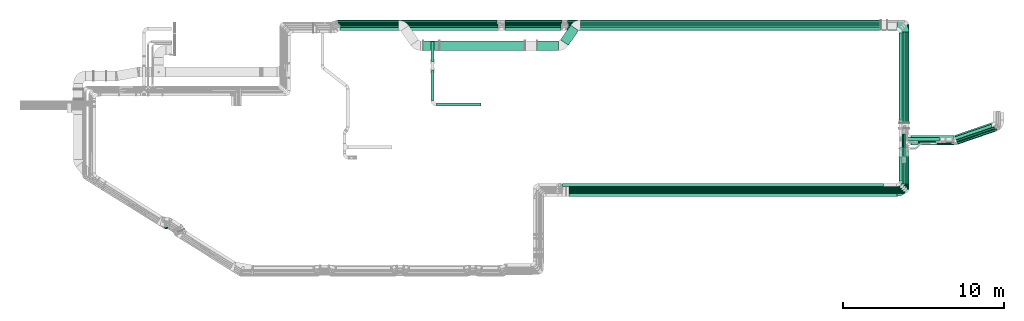
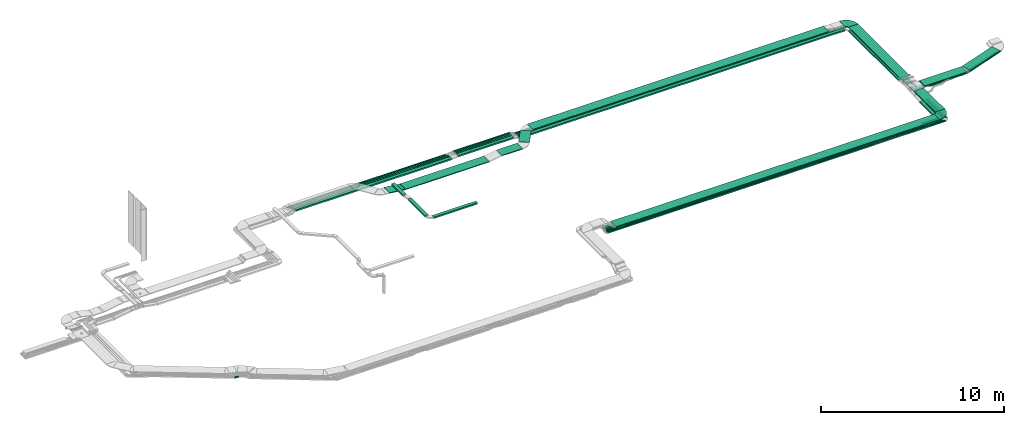
# One storey, part 4 of 28: 56 flow segments, 2 flow fittings.
"""IFC2X3 building model written with IfcOpenShell, lengths in millimetres."""

from ifc_helpers import new_model, entity, si_unit, converted_unit, derived_unit, direction, frame, frame_2d, origin, origin_2d_with_axis, place, context, subcontext, project, spatial, polyline, circle_curve, parameter, trimmed, segment, composite_curve, rectangle, outline, extrude, source, transform, mapped, material, type_object, type_shapes, element, save


model = new_model("IFC2X3")

# Units and contexts
model_context = context("Model", 3, precision=0.01, world=origin(), true_north=direction((6.12303176911189e-17, 1.0)))
body_context = subcontext(model_context, "Body", "Model", "MODEL_VIEW")
ifc_project = project(units=[si_unit("LENGTHUNIT", "METRE", prefix="MILLI"), si_unit("AREAUNIT", "SQUARE_METRE"), si_unit("VOLUMEUNIT", "CUBIC_METRE"), converted_unit("PLANEANGLEUNIT", "DEGREE", entity("IfcRatioMeasure", 0.0174532925199433), si_unit("PLANEANGLEUNIT", "RADIAN"), dimensions=[0, 0, 0, 0, 0, 0, 0]), si_unit("MASSUNIT", "GRAM", prefix="KILO"), derived_unit("MASSDENSITYUNIT", [(si_unit("MASSUNIT", "GRAM", prefix="KILO"), 1), (si_unit("LENGTHUNIT", "METRE"), -3)]), derived_unit("MOMENTOFINERTIAUNIT", [(si_unit("LENGTHUNIT", "METRE"), 4)]), si_unit("TIMEUNIT", "SECOND"), si_unit("FREQUENCYUNIT", "HERTZ"), si_unit("THERMODYNAMICTEMPERATUREUNIT", "DEGREE_CELSIUS"), derived_unit("THERMALTRANSMITTANCEUNIT", [(si_unit("MASSUNIT", "GRAM", prefix="KILO"), 1), (si_unit("THERMODYNAMICTEMPERATUREUNIT", "KELVIN"), -1), (si_unit("TIMEUNIT", "SECOND"), -3)]), derived_unit("VOLUMETRICFLOWRATEUNIT", [(si_unit("LENGTHUNIT", "METRE"), 3), (si_unit("TIMEUNIT", "SECOND"), -1)]), derived_unit("MASSFLOWRATEUNIT", [(si_unit("MASSUNIT", "GRAM", prefix="KILO"), 1), (si_unit("TIMEUNIT", "SECOND"), -1)]), derived_unit("ROTATIONALFREQUENCYUNIT", [(si_unit("TIMEUNIT", "SECOND"), -1)]), si_unit("ELECTRICCURRENTUNIT", "AMPERE"), si_unit("ELECTRICVOLTAGEUNIT", "VOLT"), si_unit("POWERUNIT", "WATT"), si_unit("FORCEUNIT", "NEWTON", prefix="KILO"), si_unit("ILLUMINANCEUNIT", "LUX"), si_unit("LUMINOUSFLUXUNIT", "LUMEN"), si_unit("LUMINOUSINTENSITYUNIT", "CANDELA"), derived_unit("USERDEFINED", [(si_unit("MASSUNIT", "GRAM", prefix="KILO"), -1), (si_unit("LENGTHUNIT", "METRE"), -2), (si_unit("TIMEUNIT", "SECOND"), 3), (si_unit("LUMINOUSFLUXUNIT", "LUMEN"), 1)]), derived_unit("LINEARVELOCITYUNIT", [(si_unit("LENGTHUNIT", "METRE"), 1), (si_unit("TIMEUNIT", "SECOND"), -1)]), si_unit("PRESSUREUNIT", "PASCAL"), derived_unit("USERDEFINED", [(si_unit("LENGTHUNIT", "METRE"), -2), (si_unit("MASSUNIT", "GRAM", prefix="KILO"), 1), (si_unit("TIMEUNIT", "SECOND"), -2)]), derived_unit("LINEARFORCEUNIT", [(si_unit("MASSUNIT", "GRAM", prefix="KILO"), 1), (si_unit("LENGTHUNIT", "METRE"), 1), (si_unit("TIMEUNIT", "SECOND"), -2), (si_unit("LENGTHUNIT", "METRE"), -1)]), derived_unit("PLANARFORCEUNIT", [(si_unit("MASSUNIT", "GRAM", prefix="KILO"), 1), (si_unit("LENGTHUNIT", "METRE"), 1), (si_unit("TIMEUNIT", "SECOND"), -2), (si_unit("LENGTHUNIT", "METRE"), -2)])], contexts=[model_context])

# Site, building, storey
site_placement = place(None, origin())
site = spatial("IfcSite", under=ifc_project, at=site_placement, CompositionType="ELEMENT")
building_placement = place(site_placement, origin())
building = spatial("IfcBuilding", under=site, at=building_placement, CompositionType="ELEMENT")
storey_placement = place(building_placement, frame((0.0, 0.0, 4200.0)))
storey = spatial("IfcBuildingStorey", under=building, at=storey_placement, CompositionType="ELEMENT", Elevation=4200.0)

# Flow segments
cable_carrier_segment_type = type_object("IfcCableCarrierSegmentType", PredefinedType="CABLETRAYSEGMENT")
flow_segment_1_placement = place(storey_placement, frame((60531.45, 5610.19, 2500.0)))
element("IfcFlowSegment", 1, at=flow_segment_1_placement, inside=storey, type_object=cable_carrier_segment_type, context=body_context, shape_type="SweptSolid", body=[
    extrude(rectangle(XDim=1096.23000000496, YDim=99.9999999999989, at=origin_2d_with_axis()), frame((548.12, 50.0, 0.0)), (0.0, 0.0, 1.0), 99.9999999999989),
])
flow_segment_2_placement = place(storey_placement, frame((40879.69, 15938.42, 2546.7)))
element("IfcFlowSegment", 2, at=flow_segment_2_placement, inside=storey, type_object=cable_carrier_segment_type, context=body_context, shape_type="SweptSolid", body=[
    extrude(rectangle(XDim=20847.646391026, YDim=99.9999999999989, at=origin_2d_with_axis()), frame((10423.82, 50.0, 0.0)), (0.0, 0.0, 1.0), 49.9999999999995),
])
flow_segment_3_placement = place(storey_placement, frame((32941.59, 14271.85, 2674.66)))
element("IfcFlowSegment", 3, at=flow_segment_3_placement, inside=storey, type_object=cable_carrier_segment_type, context=body_context, shape_type="SweptSolid", body=[
    extrude(rectangle(XDim=5286.86759215359, YDim=600.000000000002, at=origin_2d_with_axis()), frame((2643.43, 300.0, 0.0)), (0.0, 0.0, 1.0), 49.9999999999995),
])
flow_segment_4_placement = place(storey_placement, frame((31926.78, 14271.85, 2675.78)))
element("IfcFlowSegment", 4, at=flow_segment_4_placement, inside=storey, type_object=cable_carrier_segment_type, context=body_context, shape_type="SweptSolid", body=[
    extrude(rectangle(XDim=50.000000000001, YDim=600.000000000002, at=frame_2d((0.0, 0.0), x_axis=(0.0, 1.0))), frame((2.91, 300.0, 141.47), z_axis=(0.993206062484992, 0.0, -0.116368885201576), x_axis=(0.0, 1.0, 0.0)), (0.0, 0.0, 1.0), 1002.35179537027),
])
flow_segment_5_placement = place(storey_placement, frame((40446.5, 14592.48, 2798.17)))
element("IfcFlowSegment", 5, at=flow_segment_5_placement, inside=storey, type_object=cable_carrier_segment_type, context=body_context, shape_type="SweptSolid", body=[
    extrude(rectangle(XDim=1109.5441562498, YDim=599.999999999997, at=origin_2d_with_axis()), frame((563.95, 626.52, 0.0), z_axis=(0.0, 0.0, 1.0), x_axis=(-0.573576436351054, -0.819152044288987, 0.0)), (0.0, 0.0, 1.0), 49.9999999999995),
])
flow_segment_6_placement = place(storey_placement, frame((39015.98, 14271.85, 2798.17)))
element("IfcFlowSegment", 6, at=flow_segment_6_placement, inside=storey, type_object=cable_carrier_segment_type, context=body_context, shape_type="SweptSolid", body=[
    extrude(rectangle(XDim=1306.06718726911, YDim=600.000000000002, at=origin_2d_with_axis()), frame((653.03, 300.0, 0.0)), (0.0, 0.0, 1.0), 49.9999999999995),
])
flow_segment_7_placement = place(storey_placement, frame((26552.17, 16039.18, 2639.21)))
element("IfcFlowSegment", 7, at=flow_segment_7_placement, inside=storey, type_object=cable_carrier_segment_type, context=body_context, shape_type="SweptSolid", body=[
    extrude(rectangle(XDim=9961.15558282247, YDim=99.9999999999989, at=origin_2d_with_axis()), frame((4980.58, 50.0, 0.0), z_axis=(0.0, 0.0, 1.0), x_axis=(-1.0, 0.0, 0.0)), (0.0, 0.0, 1.0), 49.9999999999995),
])
flow_segment_8_placement = place(storey_placement, frame((26760.66, 15519.49, 2639.21)))
element("IfcFlowSegment", 8, at=flow_segment_8_placement, inside=storey, type_object=cable_carrier_segment_type, context=body_context, shape_type="SweptSolid", body=[
    extrude(rectangle(XDim=9824.01158628356, YDim=199.999999999998, at=origin_2d_with_axis()), frame((4912.01, 100.0, 0.0)), (0.0, 0.0, 1.0), 99.9999999999989),
])
flow_segment_9_placement = place(storey_placement, frame((26772.9, 15728.42, 2634.95)))
element("IfcFlowSegment", 9, at=flow_segment_9_placement, inside=storey, type_object=cable_carrier_segment_type, context=body_context, shape_type="SweptSolid", body=[
    extrude(rectangle(XDim=9811.7674338486, YDim=99.9999999999989, at=origin_2d_with_axis()), frame((4905.88, 50.0, 0.0)), (0.0, 0.0, 1.0), 99.9999999999989),
])
flow_segment_10_placement = place(storey_placement, frame((26698.01, 15833.42, 2639.21)))
element("IfcFlowSegment", 10, at=flow_segment_10_placement, inside=storey, type_object=cable_carrier_segment_type, context=body_context, shape_type="SweptSolid", body=[
    extrude(rectangle(XDim=9886.65329795796, YDim=99.9999999999989, at=origin_2d_with_axis()), frame((4943.33, 50.0, 0.0)), (0.0, 0.0, 1.0), 100.000000000001),
])
flow_segment_11_placement = place(storey_placement, frame((26622.17, 15938.42, 2639.21)))
element("IfcFlowSegment", 11, at=flow_segment_11_placement, inside=storey, type_object=cable_carrier_segment_type, context=body_context, shape_type="SweptSolid", body=[
    extrude(rectangle(XDim=9891.15558282195, YDim=99.9999999999989, at=origin_2d_with_axis()), frame((4945.58, 50.0, 0.0), z_axis=(0.0, 0.0, 1.0), x_axis=(-1.0, 0.0, 0.0)), (0.0, 0.0, 1.0), 49.9999999999995),
])
flow_segment_12_placement = place(storey_placement, frame((60516.45, 5505.19, 2500.0)))
element("IfcFlowSegment", 12, at=flow_segment_12_placement, inside=storey, type_object=cable_carrier_segment_type, context=body_context, shape_type="SweptSolid", body=[
    extrude(rectangle(XDim=1209.97480888635, YDim=99.999999999999, at=origin_2d_with_axis()), frame((604.99, 50.0, 0.0)), (0.0, 0.0, 1.0), 49.9999999999995),
])
flow_segment_13_placement = place(storey_placement, frame((60526.45, 5715.19, 2500.0)))
element("IfcFlowSegment", 13, at=flow_segment_13_placement, inside=storey, type_object=cable_carrier_segment_type, context=body_context, shape_type="SweptSolid", body=[
    extrude(rectangle(XDim=998.830474924462, YDim=99.9999999999989, at=origin_2d_with_axis()), frame((499.42, 50.0, 0.0)), (0.0, 0.0, 1.0), 100.000000000001),
])
flow_segment_14_placement = place(storey_placement, frame((61676.28, 5966.19, 2500.0)))
element("IfcFlowSegment", 14, at=flow_segment_14_placement, inside=storey, type_object=cable_carrier_segment_type, context=body_context, shape_type="SweptSolid", body=[
    extrude(rectangle(XDim=1336.14812837233, YDim=99.9999999999946, at=origin_2d_with_axis()), frame((50.0, 668.07, 0.0), z_axis=(0.0, 0.0, 1.0), x_axis=(0.0, 1.0, 0.0)), (0.0, 0.0, 1.0), 100.000000000001),
])
flow_segment_15_placement = place(storey_placement, frame((40965.98, 5216.66, 2859.5)))
element("IfcFlowSegment", 15, at=flow_segment_15_placement, inside=storey, type_object=cable_carrier_segment_type, context=body_context, shape_type="SweptSolid", body=[
    extrude(rectangle(XDim=20377.0563312766, YDim=600.0, at=origin_2d_with_axis()), frame((10188.53, 300.0, 0.0), z_axis=(0.0, 0.0, 1.0), x_axis=(-1.0, 0.0, 0.0)), (0.0, 0.0, 1.0), 49.9999999999995),
])
flow_segment_16_placement = place(storey_placement, frame((61982.18, 5651.19, 2500.0)))
element("IfcFlowSegment", 16, at=flow_segment_16_placement, inside=storey, type_object=cable_carrier_segment_type, context=body_context, shape_type="SweptSolid", body=[
    extrude(rectangle(XDim=2060.92376704407, YDim=99.9999999999946, at=origin_2d_with_axis()), frame((50.0, 1030.46, 0.0), z_axis=(0.0, 0.0, 1.0), x_axis=(0.0, -1.0, 0.0)), (0.0, 0.0, 1.0), 49.9999999999995),
])
flow_segment_17_placement = place(storey_placement, frame((61494.03, 9777.91, 2773.4)))
element("IfcFlowSegment", 17, at=flow_segment_17_placement, inside=storey, type_object=cable_carrier_segment_type, context=body_context, shape_type="SweptSolid", body=[
    extrude(rectangle(XDim=5637.24684915034, YDim=600.000000000002, at=origin_2d_with_axis()), frame((300.0, 2818.62, 0.0), z_axis=(0.0, 0.0, 1.0), x_axis=(0.0, -1.0, 0.0)), (0.0, 0.0, 1.0), 49.9999999999995),
])
flow_segment_18_placement = place(storey_placement, frame((61494.03, 5967.66, 2859.5)))
element("IfcFlowSegment", 18, at=flow_segment_18_placement, inside=storey, type_object=cable_carrier_segment_type, context=body_context, shape_type="SweptSolid", body=[
    extrude(rectangle(XDim=2295.66681678748, YDim=600.000000000002, at=origin_2d_with_axis()), frame((300.0, 1147.83, 0.0), z_axis=(0.0, 0.0, 1.0), x_axis=(0.0, 1.0, 0.0)), (0.0, 0.0, 1.0), 49.9999999999995),
])
flow_segment_19_placement = place(storey_placement, frame((62224.03, 8393.32, 2859.5)))
element("IfcFlowSegment", 19, at=flow_segment_19_placement, inside=storey, type_object=cable_carrier_segment_type, context=body_context, shape_type="SweptSolid", body=[
    extrude(rectangle(XDim=2650.5603253686, YDim=599.999999980996, at=origin_2d_with_axis()), frame((1325.28, 300.0, 0.01), z_axis=(-7.95923313382307e-06, 0.0, 1.0), x_axis=(-1.0, 0.0, -7.95923313382307e-06)), (0.0, 0.0, 1.0), 49.9999999984147),
])
flow_segment_20_placement = place(storey_placement, frame((40879.68, 16039.18, 2546.71)))
element("IfcFlowSegment", 20, at=flow_segment_20_placement, inside=storey, type_object=cable_carrier_segment_type, context=body_context, shape_type="SweptSolid", body=[
    extrude(rectangle(XDim=19890.0764714327, YDim=99.9999999999989, at=origin_2d_with_axis()), frame((9945.04, 50.0, 0.0), z_axis=(0.0, 0.0, 1.0), x_axis=(-1.0, 0.0, 0.0)), (0.0, 0.0, 1.0), 49.9999999999995),
])
flow_segment_21_placement = place(storey_placement, frame((61982.18, 8367.18, 2577.31)))
element("IfcFlowSegment", 21, at=flow_segment_21_placement, inside=storey, type_object=cable_carrier_segment_type, context=body_context, shape_type="SweptSolid", body=[
    extrude(rectangle(XDim=7520.99417146538, YDim=99.9999999999946, at=origin_2d_with_axis()), frame((50.0, 3760.5, 0.0), z_axis=(0.0, 0.0, 1.0), x_axis=(0.0, -1.0, 0.0)), (0.0, 0.0, 1.0), 49.9999999999995),
])
flow_segment_22_placement = place(storey_placement, frame((41698.84, 15566.15, 2798.17)))
element("IfcFlowSegment", 22, at=flow_segment_22_placement, inside=storey, type_object=cable_carrier_segment_type, context=body_context, shape_type="SweptSolid", body=[
    extrude(rectangle(XDim=18645.0038607137, YDim=600.000000000002, at=origin_2d_with_axis()), frame((9322.5, 300.0, 0.0)), (0.0, 0.0, 1.0), 49.9999999999995),
])
flow_segment_23_placement = place(storey_placement, frame((40581.18, 5820.37, 2500.0)))
element("IfcFlowSegment", 23, at=flow_segment_23_placement, inside=storey, type_object=cable_carrier_segment_type, context=body_context, shape_type="SweptSolid", body=[
    extrude(rectangle(XDim=19937.7300000051, YDim=200.0, at=origin_2d_with_axis()), frame((9968.87, 100.0, 0.0)), (0.0, 0.0, 1.0), 99.9999999999989),
])
flow_segment_24_placement = place(storey_placement, frame((40581.18, 5715.19, 2500.0)))
element("IfcFlowSegment", 24, at=flow_segment_24_placement, inside=storey, type_object=cable_carrier_segment_type, context=body_context, shape_type="SweptSolid", body=[
    extrude(rectangle(XDim=19942.7300000051, YDim=99.9999999999989, at=origin_2d_with_axis()), frame((9971.37, 50.0, 0.0)), (0.0, 0.0, 1.0), 100.000000000001),
])
flow_segment_25_placement = place(storey_placement, frame((40581.18, 5610.19, 2500.0)))
element("IfcFlowSegment", 25, at=flow_segment_25_placement, inside=storey, type_object=cable_carrier_segment_type, context=body_context, shape_type="SweptSolid", body=[
    extrude(rectangle(XDim=19947.7300000051, YDim=100.000000000001, at=origin_2d_with_axis()), frame((9973.87, 50.0, 0.0)), (0.0, 0.0, 1.0), 99.9999999999989),
])
flow_segment_26_placement = place(storey_placement, frame((40556.18, 5505.19, 2500.0)))
element("IfcFlowSegment", 26, at=flow_segment_26_placement, inside=storey, type_object=cable_carrier_segment_type, context=body_context, shape_type="SweptSolid", body=[
    extrude(rectangle(XDim=19957.730000005, YDim=99.9999999999989, at=origin_2d_with_axis()), frame((9978.87, 50.0, 0.0)), (0.0, 0.0, 1.0), 49.9999999999995),
])
flow_segment_27_placement = place(storey_placement, frame((40556.18, 5400.19, 2500.0)))
element("IfcFlowSegment", 27, at=flow_segment_27_placement, inside=storey, type_object=cable_carrier_segment_type, context=body_context, shape_type="SweptSolid", body=[
    extrude(rectangle(XDim=19930.0, YDim=100.000000000001, at=origin_2d_with_axis()), frame((9965.0, 50.0, 0.0)), (0.0, 0.0, 1.0), 49.9999999999995),
])
flow_segment_28_placement = place(storey_placement, frame((64925.16, 8434.14, 2859.5)))
element("IfcFlowSegment", 28, at=flow_segment_28_placement, inside=storey, type_object=cable_carrier_segment_type, context=body_context, shape_type="SweptSolid", body=[
    extrude(rectangle(XDim=2487.12933777022, YDim=599.99999998332, at=origin_2d_with_axis()), frame((1273.67, 686.88, 0.01), z_axis=(7.05330622754615e-06, 2.41667209379348e-06, 1.0), x_axis=(-0.946011941325012, -0.324131773843437, 7.45583212984717e-06)), (0.0, 0.0, 1.0), 49.9999999986095),
])
flow_segment_29_placement = place(storey_placement, frame((64833.04, 8683.01, 2637.16)))
element("IfcFlowSegment", 29, at=flow_segment_29_placement, inside=storey, type_object=cable_carrier_segment_type, context=body_context, shape_type="SweptSolid", body=[
    extrude(rectangle(XDim=2497.74962701642, YDim=199.999999999999, at=origin_2d_with_axis()), frame((1213.86, 499.4, 0.0), z_axis=(0.0, 0.0, 1.0), x_axis=(-0.946011941351309, -0.324131773852438, 0.0)), (0.0, 0.0, 1.0), 99.9999999999989),
])
flow_segment_30_placement = place(storey_placement, frame((64851.9, 8561.27, 2683.27)))
element("IfcFlowSegment", 30, at=flow_segment_30_placement, inside=storey, type_object=cable_carrier_segment_type, context=body_context, shape_type="SweptSolid", body=[
    extrude(rectangle(XDim=99.9999999999977, YDim=2718.37001709308, at=frame_2d((0.0, 0.0), x_axis=(0.0, 1.0))), frame((1302.01, 487.86, 0.01), z_axis=(4.88705511669176e-05, -0.000142633733295683, 0.999999988633644), x_axis=(0.946011941351311, 0.324131773852431, 0.0)), (0.0, 0.0, 1.0), 50.0000000000005),
])
flow_segment_31_placement = place(storey_placement, frame((64998.65, 8457.37, 2750.03)))
element("IfcFlowSegment", 31, at=flow_segment_31_placement, inside=storey, type_object=cable_carrier_segment_type, context=body_context, shape_type="SweptSolid", body=[
    extrude(rectangle(XDim=100.000000000002, YDim=2692.23250721173, at=frame_2d((0.0, 0.0), x_axis=(0.0, 1.0))), frame((1289.65, 483.63, 0.01), z_axis=(3.97531317744237e-05, -0.000116023606441738, 0.999999992479106), x_axis=(0.946011941351311, 0.324131773852432, 0.0)), (0.0, 0.0, 1.0), 49.9999999999991),
])
flow_segment_32_placement = place(storey_placement, frame((61471.18, 6171.37, 2500.0)))
element("IfcFlowSegment", 32, at=flow_segment_32_placement, inside=storey, type_object=cable_carrier_segment_type, context=body_context, shape_type="SweptSolid", body=[
    extrude(rectangle(XDim=1456.20731160175, YDim=200.000000000007, at=origin_2d_with_axis()), frame((100.0, 728.1, 0.0), z_axis=(0.0, 0.0, 1.0), x_axis=(0.0, 1.0, 0.0)), (0.0, 0.0, 1.0), 99.9999999999989),
])
flow_segment_33_placement = place(storey_placement, frame((62631.01, 8547.45, 2629.87)))
element("IfcFlowSegment", 33, at=flow_segment_33_placement, inside=storey, type_object=cable_carrier_segment_type, context=body_context, shape_type="SweptSolid", body=[
    extrude(rectangle(XDim=1135.7210445927, YDim=100.000000000001, at=origin_2d_with_axis()), frame((567.86, 50.0, 0.0), z_axis=(0.0, 0.0, 1.0), x_axis=(-1.0, 0.0, 0.0)), (0.0, 0.0, 1.0), 49.9999999999995),
])
flow_segment_34_placement = place(storey_placement, frame((36993.61, 15519.49, 2686.71)))
element("IfcFlowSegment", 34, at=flow_segment_34_placement, inside=storey, type_object=cable_carrier_segment_type, context=body_context, shape_type="SweptSolid", body=[
    extrude(rectangle(XDim=3486.75170485592, YDim=199.999999999998, at=origin_2d_with_axis()), frame((1743.38, 100.0, 0.0), z_axis=(0.0, 0.0, 1.0), x_axis=(-1.0, 0.0, 0.0)), (0.0, 0.0, 1.0), 99.9999999999989),
])
flow_segment_35_placement = place(storey_placement, frame((36994.13, 15728.42, 2682.51)))
element("IfcFlowSegment", 35, at=flow_segment_35_placement, inside=storey, type_object=cable_carrier_segment_type, context=body_context, shape_type="SweptSolid", body=[
    extrude(rectangle(XDim=3495.23551373344, YDim=99.9999999999989, at=origin_2d_with_axis()), frame((1747.62, 50.0, 0.0), z_axis=(0.0, 0.0, 1.0), x_axis=(-1.0, 0.0, 0.0)), (0.0, 0.0, 1.0), 100.000000000001),
])
flow_segment_36_placement = place(storey_placement, frame((36993.61, 15833.42, 2686.71)))
element("IfcFlowSegment", 36, at=flow_segment_36_placement, inside=storey, type_object=cable_carrier_segment_type, context=body_context, shape_type="SweptSolid", body=[
    extrude(rectangle(XDim=3486.75170485595, YDim=99.9999999999989, at=origin_2d_with_axis()), frame((1743.38, 50.0, 0.0), z_axis=(0.0, 0.0, 1.0), x_axis=(-1.0, 0.0, 0.0)), (0.0, 0.0, 1.0), 100.0),
])
flow_segment_37_placement = place(storey_placement, frame((36998.32, 15938.42, 2686.71)))
element("IfcFlowSegment", 37, at=flow_segment_37_placement, inside=storey, type_object=cable_carrier_segment_type, context=body_context, shape_type="SweptSolid", body=[
    extrude(rectangle(XDim=3546.73794019873, YDim=99.9999999999989, at=origin_2d_with_axis()), frame((1773.37, 50.0, 0.0), z_axis=(0.0, 0.0, 1.0), x_axis=(-1.0, 0.0, 0.0)), (0.0, 0.0, 1.0), 49.9999999999995),
])
flow_segment_38_placement = place(storey_placement, frame((36998.32, 16039.18, 2686.71)))
element("IfcFlowSegment", 38, at=flow_segment_38_placement, inside=storey, type_object=cable_carrier_segment_type, context=body_context, shape_type="SweptSolid", body=[
    extrude(rectangle(XDim=3546.73794019871, YDim=99.9999999999989, at=origin_2d_with_axis()), frame((1773.37, 50.0, 0.0), z_axis=(0.0, 0.0, 1.0), x_axis=(-1.0, 0.0, 0.0)), (0.0, 0.0, 1.0), 49.9999999999995),
])
flow_segment_39_placement = place(storey_placement, frame((15821.41, 3188.78, 2836.0)))
element("IfcFlowSegment", 39, at=flow_segment_39_placement, inside=storey, type_object=cable_carrier_segment_type, context=body_context, shape_type="SweptSolid", body=[
    extrude(rectangle(XDim=240.2478763449, YDim=99.9999999999996, at=origin_2d_with_axis()), frame((126.98, 70.1, 0.0), z_axis=(0.0, 0.0, 1.0), x_axis=(0.984807753012223, -0.173648177666844, 0.0)), (0.0, 0.0, 1.0), 49.9999999999994),
])
flow_segment_40_placement = place(storey_placement, frame((60512.45, 5400.19, 2500.0)))
element("IfcFlowSegment", 40, at=flow_segment_40_placement, inside=storey, type_object=cable_carrier_segment_type, context=body_context, shape_type="SweptSolid", body=[
    extrude(rectangle(XDim=1318.73000000509, YDim=99.9999999999989, at=origin_2d_with_axis()), frame((659.37, 50.0, 0.0)), (0.0, 0.0, 1.0), 49.9999999999995),
])
flow_segment_41_placement = place(storey_placement, frame((61778.68, 5861.19, 2500.0)))
element("IfcFlowSegment", 41, at=flow_segment_41_placement, inside=storey, type_object=cable_carrier_segment_type, context=body_context, shape_type="SweptSolid", body=[
    extrude(rectangle(XDim=1441.15238333803, YDim=99.9999999999946, at=origin_2d_with_axis()), frame((50.0, 720.58, 0.0), z_axis=(0.0, 0.0, 1.0), x_axis=(0.0, 1.0, 0.0)), (0.0, 0.0, 1.0), 99.9999999999989),
])
flow_segment_42_placement = place(storey_placement, frame((61877.43, 5756.08, 2500.0)))
element("IfcFlowSegment", 42, at=flow_segment_42_placement, inside=storey, type_object=cable_carrier_segment_type, context=body_context, shape_type="SweptSolid", body=[
    extrude(rectangle(XDim=1973.91369428736, YDim=100.0, at=origin_2d_with_axis()), frame((50.45, 986.98, 0.0), z_axis=(0.0, 0.0, 1.0), x_axis=(-0.000454223170527662, -0.99999989684065, 0.0)), (0.0, 0.0, 1.0), 50.0000000000005),
])
flow_segment_43_placement = place(storey_placement, frame((61778.68, 7659.92, 2530.73)))
element("IfcFlowSegment", 43, at=flow_segment_43_placement, inside=storey, type_object=cable_carrier_segment_type, context=body_context, shape_type="SweptSolid", body=[
    extrude(rectangle(XDim=1431.01738845492, YDim=99.9999999999946, at=origin_2d_with_axis()), frame((50.0, 715.51, 0.0), z_axis=(0.0, 0.0, 1.0), x_axis=(0.0, -1.0, 0.0)), (0.0, 0.0, 1.0), 100.000000000001),
])
flow_segment_44_placement = place(storey_placement, frame((61676.28, 7659.93, 2530.73)))
element("IfcFlowSegment", 44, at=flow_segment_44_placement, inside=storey, type_object=cable_carrier_segment_type, context=body_context, shape_type="SweptSolid", body=[
    extrude(rectangle(XDim=1431.01812835987, YDim=99.9999999999946, at=origin_2d_with_axis()), frame((50.0, 715.51, 0.0), z_axis=(0.0, 0.0, 1.0), x_axis=(0.0, -1.0, 0.0)), (0.0, 0.0, 1.0), 100.000000000001),
])
flow_segment_45_placement = place(storey_placement, frame((61916.31, 8663.79, 2582.6)))
element("IfcFlowSegment", 45, at=flow_segment_45_placement, inside=storey, type_object=cable_carrier_segment_type, context=body_context, shape_type="SweptSolid", body=[
    extrude(rectangle(XDim=2086.73632078342, YDim=200.0, at=origin_2d_with_axis()), frame((1043.37, 100.0, 0.0), z_axis=(0.0, 0.0, 1.0), x_axis=(-1.0, 0.0, 0.0)), (0.0, 0.0, 1.0), 100.000000000001),
])
flow_segment_46_placement = place(storey_placement, frame((63812.19, 8443.55, 2750.04)))
element("IfcFlowSegment", 46, at=flow_segment_46_placement, inside=storey, type_object=cable_carrier_segment_type, context=body_context, shape_type="SweptSolid", body=[
    extrude(rectangle(XDim=1135.89967886, YDim=99.9999999209843, at=origin_2d_with_axis()), frame((567.95, 50.0, 0.02), z_axis=(3.97531320428625e-05, 0.0, 1.0), x_axis=(-1.0, 0.0, 3.97531320428625e-05)), (0.0, 0.0, 1.0), 49.9999999604926),
])
flow_segment_47_placement = place(storey_placement, frame((61471.18, 9973.92, 2546.2)))
element("IfcFlowSegment", 47, at=flow_segment_47_placement, inside=storey, type_object=cable_carrier_segment_type, context=body_context, shape_type="SweptSolid", body=[
    extrude(rectangle(XDim=5394.57269706876, YDim=200.000000000007, at=origin_2d_with_axis()), frame((100.0, 2697.29, 0.0), z_axis=(0.0, 0.0, 1.0), x_axis=(0.0, 1.0, 0.0)), (0.0, 0.0, 1.0), 99.9999999999989),
])
flow_segment_48_placement = place(storey_placement, frame((40837.01, 15519.49, 2546.77)))
element("IfcFlowSegment", 48, at=flow_segment_48_placement, inside=storey, type_object=cable_carrier_segment_type, context=body_context, shape_type="SweptSolid", body=[
    extrude(rectangle(XDim=20483.1778787901, YDim=199.999999999998, at=origin_2d_with_axis()), frame((10241.59, 100.0, 0.0)), (0.0, 0.0, 1.0), 99.9999999999989),
])
flow_segment_49_placement = place(storey_placement, frame((61676.28, 9371.81, 2503.42)))
element("IfcFlowSegment", 49, at=flow_segment_49_placement, inside=storey, type_object=cable_carrier_segment_type, context=body_context, shape_type="SweptSolid", body=[
    extrude(rectangle(XDim=6205.60445609864, YDim=99.9999999999946, at=origin_2d_with_axis()), frame((50.0, 3102.8, 0.0), z_axis=(0.0, 0.0, 1.0), x_axis=(0.0, 1.0, 0.0)), (0.0, 0.0, 1.0), 99.9999999999989),
])
flow_segment_50_placement = place(storey_placement, frame((40929.0, 15728.42, 2503.87)))
element("IfcFlowSegment", 50, at=flow_segment_50_placement, inside=storey, type_object=cable_carrier_segment_type, context=body_context, shape_type="SweptSolid", body=[
    extrude(rectangle(XDim=20596.2819049685, YDim=99.9999999999989, at=origin_2d_with_axis()), frame((10298.14, 50.0, 0.0)), (0.0, 0.0, 1.0), 99.9999999999989),
])
flow_segment_51_placement = place(storey_placement, frame((40929.94, 15833.42, 2503.44)))
element("IfcFlowSegment", 51, at=flow_segment_51_placement, inside=storey, type_object=cable_carrier_segment_type, context=body_context, shape_type="SweptSolid", body=[
    extrude(rectangle(XDim=20697.7459592251, YDim=99.9999999999989, at=origin_2d_with_axis()), frame((10348.87, 50.0, 0.0)), (0.0, 0.0, 1.0), 100.000000000001),
])
flow_segment_52_placement = place(storey_placement, frame((61778.68, 9609.38, 2503.44)))
element("IfcFlowSegment", 52, at=flow_segment_52_placement, inside=storey, type_object=cable_carrier_segment_type, context=body_context, shape_type="SweptSolid", body=[
    extrude(rectangle(XDim=6073.03640981325, YDim=99.9999999999946, at=origin_2d_with_axis()), frame((50.0, 3036.52, 0.0), z_axis=(0.0, 0.0, 1.0), x_axis=(0.0, -1.0, 0.0)), (0.0, 0.0, 1.0), 100.000000000001),
])
flow_segment_53_placement = place(storey_placement, frame((61878.34, 9307.1, 2546.7)))
element("IfcFlowSegment", 53, at=flow_segment_53_placement, inside=storey, type_object=cable_carrier_segment_type, context=body_context, shape_type="SweptSolid", body=[
    extrude(rectangle(XDim=6480.31970590073, YDim=99.9999999999946, at=origin_2d_with_axis()), frame((50.0, 3240.16, 0.0), z_axis=(0.0, 0.0, 1.0), x_axis=(0.0, 1.0, 0.0)), (0.0, 0.0, 1.0), 49.9999999999995),
])
flow_segment_54_placement = place(storey_placement, frame((32398.88, 11166.81, 2930.0)))
element("IfcFlowSegment", 54, at=flow_segment_54_placement, inside=storey, type_object=cable_carrier_segment_type, context=body_context, shape_type="SweptSolid", body=[
    extrude(rectangle(XDim=1863.7516446428, YDim=199.999999999998, at=origin_2d_with_axis()), frame((100.0, 931.88, 0.0), z_axis=(0.0, 0.0, 1.0), x_axis=(0.0, 1.0, 0.0)), (0.0, 0.0, 1.0), 99.9999999999989),
])
flow_segment_55_placement = place(storey_placement, frame((32749.88, 10815.81, 2930.0)))
element("IfcFlowSegment", 55, at=flow_segment_55_placement, inside=storey, type_object=cable_carrier_segment_type, context=body_context, shape_type="SweptSolid", body=[
    extrude(rectangle(XDim=2749.00000000001, YDim=199.999999999998, at=origin_2d_with_axis()), frame((1374.5, 100.0, 0.0)), (0.0, 0.0, 1.0), 99.9999999999989),
])
flow_segment_56_placement = place(storey_placement, frame((32398.88, 13589.78, 2843.12)))
element("IfcFlowSegment", 56, at=flow_segment_56_placement, inside=storey, type_object=cable_carrier_segment_type, context=body_context, shape_type="SweptSolid", body=[
    extrude(rectangle(XDim=1254.75164464291, YDim=199.999999999998, at=origin_2d_with_axis()), frame((100.0, 627.38, 0.0), z_axis=(0.0, 0.0, 1.0), x_axis=(0.0, 1.0, 0.0)), (0.0, 0.0, 1.0), 99.9999999999989),
])

# Flow fittings
ifc_material = material()
cable_carrier_fitting_type = type_object("IfcCableCarrierFittingType", Name="470_DKC_S5_Variable Angle Elbow 0-45:-", PredefinedType="NOTDEFINED", material=ifc_material)
shared_shape = source(origin(), body_context, "Body", "SweptSolid", [
    extrude(outline(composite_curve([segment(polyline([(-225.75, -525.25), (-224.75, -525.25)]), True, "CONTINUOUS"), segment(trimmed(circle_curve(frame_2d((-224.75, 224.75), x_axis=(0.0, -1.0)), 750.0), [parameter(0.0)], [parameter(90.0)], True, "PARAMETER"), True, "CONTINUOUS"), segment(polyline([(525.25, 224.75), (525.25, 225.75)]), True, "CONTINUOUS"), segment(polyline([(525.25, 225.75), (-74.75, 225.75)]), True, "CONTINUOUS"), segment(polyline([(-74.75, 225.75), (-74.75, 224.75)]), True, "CONTINUOUS"), segment(trimmed(circle_curve(frame_2d((-224.75, 224.75), x_axis=(0.0, -1.0)), 150.0), [parameter(0.0)], [parameter(90.0000000000001)], True, "PARAMETER"), False, "CONTINUOUS"), segment(polyline([(-224.75, 74.75), (-225.75, 74.75)]), True, "CONTINUOUS"), segment(polyline([(-225.75, 74.75), (-225.75, -525.25)]), True, "CONTINUOUS")], self_intersect=False)), frame((-225.25, 225.25, -25.0)), (0.0, 0.0, 1.0), 50.0000000000082),
])
type_shapes(cable_carrier_fitting_type, [shared_shape])
flow_fitting_1_placement = place(storey_placement, frame((61794.03, 5516.66, 2884.5)))
element("IfcFlowFitting", 57, at=flow_fitting_1_placement, inside=storey, type_object=cable_carrier_fitting_type, material=ifc_material, Name="470_DKC_S5_Variable Angle Elbow 0-45:-", ObjectType="470_DKC_S5_Variable Angle Elbow 0-45:-", context=body_context, shape_type="MappedRepresentation", body=[
    mapped(shared_shape, transform((0.0, 0.0, 0.0), scale=1.0)),
])
flow_fitting_2_placement = place(storey_placement, frame((61794.03, 15866.15, 2798.4), z_axis=(0.0, 0.0, 1.0), x_axis=(0.0, 1.0, 0.0)))
element("IfcFlowFitting", 58, at=flow_fitting_2_placement, inside=storey, type_object=cable_carrier_fitting_type, material=ifc_material, Name="470_DKC_S5_Variable Angle Elbow 0-45:-", ObjectType="470_DKC_S5_Variable Angle Elbow 0-45:-", context=body_context, shape_type="MappedRepresentation", body=[
    mapped(shared_shape, transform((0.0, 0.0, 0.0), scale=1.0)),
])

save(model, "model.ifc")
